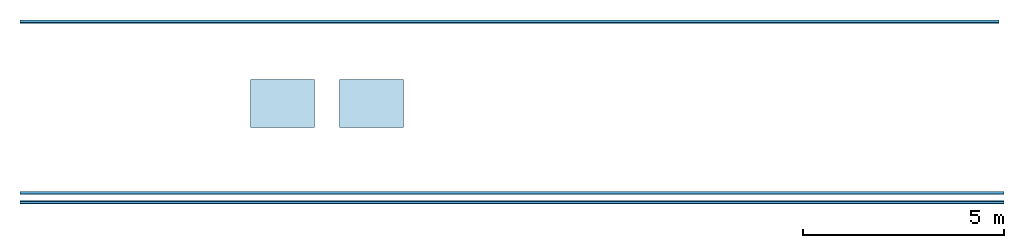
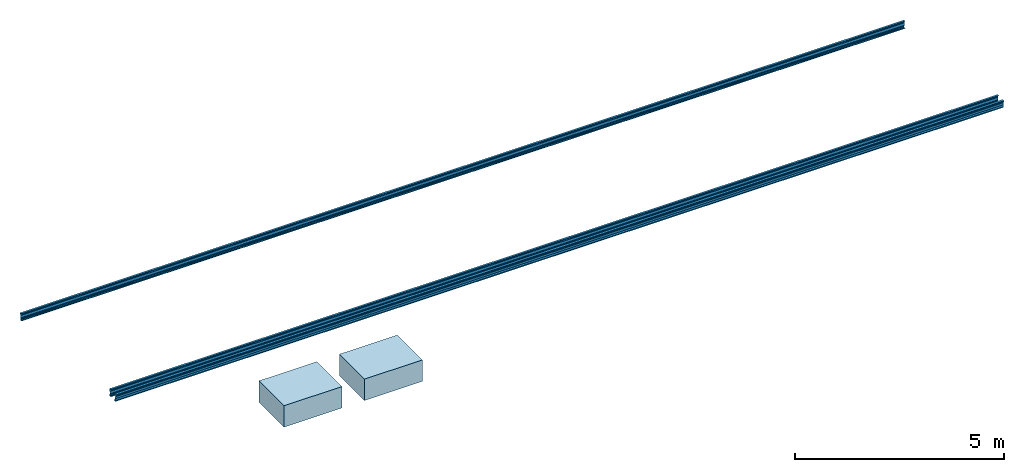
# One storey: 3 beams, 2 slabs.
"""IFC2X3 building model written with IfcOpenShell, lengths in millimetres."""

from ifc_helpers import new_model, entity, si_unit, converted_unit, money_unit, point, direction, frame, frame_2d, origin_with_axes, place, context, subcontext, project, spatial, polyline, circle_curve, parameter, trimmed, segment, composite_curve, outline, extrude, material, layer, layer_set, layer_usage, type_object, element, save


model = new_model("IFC2X3")

# Units and contexts
model_context = context("Model", 3, precision=1e-05, world=origin_with_axes(), true_north=direction((0.0, 1.0)))
body_context = subcontext(model_context, "Body", "Model", "MODEL_VIEW")
ifc_project = project(units=[si_unit("LENGTHUNIT", "METRE", prefix="MILLI"), si_unit("AREAUNIT", "SQUARE_METRE"), si_unit("VOLUMEUNIT", "CUBIC_METRE"), converted_unit("PLANEANGLEUNIT", "DEGREE", entity("IfcPlaneAngleMeasure", 0.0174532925199), si_unit("PLANEANGLEUNIT", "RADIAN"), dimensions=[0, 0, 0, 0, 0, 0, 0]), si_unit("SOLIDANGLEUNIT", "STERADIAN"), money_unit("USD"), converted_unit("TIMEUNIT", "Year", entity("IfcTimeMeasure", 31556926.0), si_unit("TIMEUNIT", "SECOND"), dimensions=[0, 0, 0, 0, 0, 0, 0]), si_unit("MASSUNIT", "GRAM"), si_unit("THERMODYNAMICTEMPERATUREUNIT", "DEGREE_CELSIUS"), si_unit("LUMINOUSINTENSITYUNIT", "LUMEN")], contexts=[model_context])

# Site, building, storey
site_placement = place(None, origin_with_axes())
site = spatial("IfcSite", under=ifc_project, at=site_placement, CompositionType="ELEMENT")
building_placement = place(site_placement, origin_with_axes())
building = spatial("IfcBuilding", under=site, at=building_placement, CompositionType="ELEMENT")
storey_placement = place(building_placement, frame((0.0, 0.0, 74905.0), z_axis=(0.0, 0.0, 1.0), x_axis=(1.0, 0.0, 0.0)))
storey = spatial("IfcBuildingStorey", under=building, at=storey_placement, Name="RIDGE", CompositionType="ELEMENT", Elevation=74905.0)

# Beams
ifc_material_1 = material(Name="Metal - Steel 43-275")
beam_type_1 = type_object("IfcBeamType", PredefinedType="NOTDEFINED")
beam_1_placement = place(storey_placement, frame((16287.2045075, 7957.0357036, -578.908435604), z_axis=(0.0, 0.0, 1.0), x_axis=(0.0, 1.0, 0.0)))
element("IfcBeam", 1, at=beam_1_placement, inside=storey, type_object=beam_type_1, material=ifc_material_1, Name="Light Gauge-Kingspan Purlins:M", ObjectType="Light Gauge-Kingspan Purlins:M", context=body_context, shape_type="SweptSolid", body=[
    extrude(outline(composite_curve([segment(polyline([(-33.5333333333, -102.5), (25.0666666666, -102.5)]), True, "CONTINUOUS"), segment(trimmed(circle_curve(frame_2d((25.0666666666, -99.3), x_axis=(0.0, -1.0)), 3.2), [point((25.0666666666, -102.5)), parameter(0.0)], [point((28.2666666666, -99.3)), parameter(90.0)], True, "CARTESIAN"), True, "CONTINUOUS"), segment(polyline([(28.2666666666, -99.3), (28.2666666666, -91.7)]), True, "CONTINUOUS"), segment(trimmed(circle_curve(frame_2d((25.0666666666, -91.7), x_axis=(1.0, 0.0)), 3.2), [point((28.2666666666, -91.7)), parameter(0.0)], [point((25.0666666666, -88.5)), parameter(90.0)], True, "CARTESIAN"), True, "CONTINUOUS"), segment(polyline([(25.0666666666, -88.5), (16.2666666666, -88.5), (16.2666666666, -90.1), (25.0666666666, -90.1)]), True, "CONTINUOUS"), segment(trimmed(circle_curve(frame_2d((25.0666666666, -91.7), x_axis=(1.0, 0.0)), 1.6), [point((25.0666666666, -90.1)), parameter(90.0)], [point((26.6666666666, -91.7)), parameter(0.0)], False, "CARTESIAN"), True, "CONTINUOUS"), segment(polyline([(26.6666666666, -91.7), (26.6666666666, -99.3)]), True, "CONTINUOUS"), segment(trimmed(circle_curve(frame_2d((25.0666666666, -99.3), x_axis=(0.0, -1.0)), 1.6), [point((26.6666666666, -99.3)), parameter(90.0)], [point((25.0666666666, -100.9)), parameter(0.0)], False, "CARTESIAN"), True, "CONTINUOUS"), segment(polyline([(25.0666666666, -100.9), (-33.5333333334, -100.9)]), True, "CONTINUOUS"), segment(trimmed(circle_curve(frame_2d((-33.5333333334, -99.3), x_axis=(-1.0, 0.0)), 1.6), [point((-33.5333333334, -100.9)), parameter(90.0)], [point((-35.1333333334, -99.3)), parameter(0.0)], False, "CARTESIAN"), True, "CONTINUOUS"), segment(polyline([(-35.1333333334, -99.3), (-35.1333333334, -70.8953456886), (-15.1333333334, -32.8953456886), (-15.1333333334, 32.8953456886), (-35.1333333334, 70.8953456886), (-35.1333333334, 99.3)]), True, "CONTINUOUS"), segment(trimmed(circle_curve(frame_2d((-33.5333333334, 99.3), x_axis=(0.0, 1.0)), 1.6), [point((-35.1333333334, 99.3)), parameter(90.0)], [point((-33.5333333334, 100.9)), parameter(0.0)], False, "CARTESIAN"), True, "CONTINUOUS"), segment(polyline([(-33.5333333334, 100.9), (25.0666666666, 100.9)]), True, "CONTINUOUS"), segment(trimmed(circle_curve(frame_2d((25.0666666666, 99.3), x_axis=(1.0, 0.0)), 1.6), [point((25.0666666666, 100.9)), parameter(90.0)], [point((26.6666666666, 99.3)), parameter(0.0)], False, "CARTESIAN"), True, "CONTINUOUS"), segment(polyline([(26.6666666666, 99.3), (26.6666666666, 91.7)]), True, "CONTINUOUS"), segment(trimmed(circle_curve(frame_2d((25.0666666666, 91.7), x_axis=(0.0, -1.0)), 1.6), [point((26.6666666666, 91.7)), parameter(90.0)], [point((25.0666666666, 90.1)), parameter(0.0)], False, "CARTESIAN"), True, "CONTINUOUS"), segment(polyline([(25.0666666666, 90.1), (16.2666666666, 90.1), (16.2666666666, 88.5), (25.0666666666, 88.5)]), True, "CONTINUOUS"), segment(trimmed(circle_curve(frame_2d((25.0666666666, 91.7), x_axis=(0.0, -1.0)), 3.2), [point((25.0666666666, 88.5)), parameter(0.0)], [point((28.2666666666, 91.7)), parameter(90.0)], True, "CARTESIAN"), True, "CONTINUOUS"), segment(polyline([(28.2666666666, 91.7), (28.2666666666, 99.3)]), True, "CONTINUOUS"), segment(trimmed(circle_curve(frame_2d((25.0666666666, 99.3), x_axis=(1.0, 0.0)), 3.2), [point((28.2666666666, 99.3)), parameter(0.0)], [point((25.0666666666, 102.5)), parameter(90.0)], True, "CARTESIAN"), True, "CONTINUOUS"), segment(polyline([(25.0666666666, 102.5), (-33.5333333334, 102.5)]), True, "CONTINUOUS"), segment(trimmed(circle_curve(frame_2d((-33.5333333334, 99.3), x_axis=(0.0, 1.0)), 3.2), [point((-33.5333333334, 102.5)), parameter(0.0)], [point((-36.7333333334, 99.3)), parameter(90.0)], True, "CARTESIAN"), True, "CONTINUOUS"), segment(polyline([(-36.7333333334, 99.3), (-36.7333333334, 70.5), (-16.7333333334, 32.5), (-16.7333333334, -32.5), (-36.7333333334, -70.5), (-36.7333333334, -99.3)]), True, "CONTINUOUS"), segment(trimmed(circle_curve(frame_2d((-33.5333333334, -99.3), x_axis=(-1.0, 0.0)), 3.20000000005), [point((-36.7333333334, -99.3)), parameter(0.0)], [point((-33.5333333333, -102.5)), parameter(90.0)], True, "CARTESIAN"), True, "CONTINUOUS")], self_intersect=False)), frame((0.0, 24407.0, 0.0), z_axis=(0.0, -1.0, 0.0), x_axis=(-0.996194698092, 0.0, 0.0871557427478)), (0.0, 0.0, 1.0), 24407.0),
])
beam_2_placement = place(storey_placement, frame((16408.2045075, 3688.12246488, -205.541205561), z_axis=(0.0, 0.0, 1.0), x_axis=(0.0, 1.0, 0.0)))
element("IfcBeam", 2, at=beam_2_placement, inside=storey, type_object=beam_type_1, material=ifc_material_1, Name="Light Gauge-Kingspan Purlins:M", ObjectType="Light Gauge-Kingspan Purlins:M", context=body_context, shape_type="SweptSolid", body=[
    extrude(outline(composite_curve([segment(polyline([(-33.5333333333, -102.5), (25.0666666666, -102.5)]), True, "CONTINUOUS"), segment(trimmed(circle_curve(frame_2d((25.0666666666, -99.3), x_axis=(0.0, -1.0)), 3.2), [point((25.0666666666, -102.5)), parameter(0.0)], [point((28.2666666666, -99.3)), parameter(90.0)], True, "CARTESIAN"), True, "CONTINUOUS"), segment(polyline([(28.2666666666, -99.3), (28.2666666666, -91.7)]), True, "CONTINUOUS"), segment(trimmed(circle_curve(frame_2d((25.0666666666, -91.7), x_axis=(1.0, 0.0)), 3.2), [point((28.2666666666, -91.7)), parameter(0.0)], [point((25.0666666666, -88.5)), parameter(90.0)], True, "CARTESIAN"), True, "CONTINUOUS"), segment(polyline([(25.0666666666, -88.5), (16.2666666666, -88.5), (16.2666666666, -90.1), (25.0666666666, -90.1)]), True, "CONTINUOUS"), segment(trimmed(circle_curve(frame_2d((25.0666666666, -91.7), x_axis=(1.0, 0.0)), 1.6), [point((25.0666666666, -90.1)), parameter(90.0)], [point((26.6666666666, -91.7)), parameter(0.0)], False, "CARTESIAN"), True, "CONTINUOUS"), segment(polyline([(26.6666666666, -91.7), (26.6666666666, -99.3)]), True, "CONTINUOUS"), segment(trimmed(circle_curve(frame_2d((25.0666666666, -99.3), x_axis=(0.0, -1.0)), 1.6), [point((26.6666666666, -99.3)), parameter(90.0)], [point((25.0666666666, -100.9)), parameter(0.0)], False, "CARTESIAN"), True, "CONTINUOUS"), segment(polyline([(25.0666666666, -100.9), (-33.5333333334, -100.9)]), True, "CONTINUOUS"), segment(trimmed(circle_curve(frame_2d((-33.5333333334, -99.3), x_axis=(-1.0, 0.0)), 1.6), [point((-33.5333333334, -100.9)), parameter(90.0)], [point((-35.1333333334, -99.3)), parameter(0.0)], False, "CARTESIAN"), True, "CONTINUOUS"), segment(polyline([(-35.1333333334, -99.3), (-35.1333333334, -70.8953456886), (-15.1333333334, -32.8953456886), (-15.1333333334, 32.8953456886), (-35.1333333334, 70.8953456886), (-35.1333333334, 99.3)]), True, "CONTINUOUS"), segment(trimmed(circle_curve(frame_2d((-33.5333333334, 99.3), x_axis=(0.0, 1.0)), 1.6), [point((-35.1333333334, 99.3)), parameter(90.0)], [point((-33.5333333334, 100.9)), parameter(0.0)], False, "CARTESIAN"), True, "CONTINUOUS"), segment(polyline([(-33.5333333334, 100.9), (25.0666666666, 100.9)]), True, "CONTINUOUS"), segment(trimmed(circle_curve(frame_2d((25.0666666666, 99.3), x_axis=(1.0, 0.0)), 1.6), [point((25.0666666666, 100.9)), parameter(90.0)], [point((26.6666666666, 99.3)), parameter(0.0)], False, "CARTESIAN"), True, "CONTINUOUS"), segment(polyline([(26.6666666666, 99.3), (26.6666666666, 91.7)]), True, "CONTINUOUS"), segment(trimmed(circle_curve(frame_2d((25.0666666666, 91.7), x_axis=(0.0, -1.0)), 1.6), [point((26.6666666666, 91.7)), parameter(90.0)], [point((25.0666666666, 90.1)), parameter(0.0)], False, "CARTESIAN"), True, "CONTINUOUS"), segment(polyline([(25.0666666666, 90.1), (16.2666666666, 90.1), (16.2666666666, 88.5), (25.0666666666, 88.5)]), True, "CONTINUOUS"), segment(trimmed(circle_curve(frame_2d((25.0666666666, 91.7), x_axis=(0.0, -1.0)), 3.2), [point((25.0666666666, 88.5)), parameter(0.0)], [point((28.2666666666, 91.7)), parameter(90.0)], True, "CARTESIAN"), True, "CONTINUOUS"), segment(polyline([(28.2666666666, 91.7), (28.2666666666, 99.3)]), True, "CONTINUOUS"), segment(trimmed(circle_curve(frame_2d((25.0666666666, 99.3), x_axis=(1.0, 0.0)), 3.2), [point((28.2666666666, 99.3)), parameter(0.0)], [point((25.0666666666, 102.5)), parameter(90.0)], True, "CARTESIAN"), True, "CONTINUOUS"), segment(polyline([(25.0666666666, 102.5), (-33.5333333334, 102.5)]), True, "CONTINUOUS"), segment(trimmed(circle_curve(frame_2d((-33.5333333334, 99.3), x_axis=(0.0, 1.0)), 3.2), [point((-33.5333333334, 102.5)), parameter(0.0)], [point((-36.7333333334, 99.3)), parameter(90.0)], True, "CARTESIAN"), True, "CONTINUOUS"), segment(polyline([(-36.7333333334, 99.3), (-36.7333333334, 70.5), (-16.7333333334, 32.5), (-16.7333333334, -32.5), (-36.7333333334, -70.5), (-36.7333333334, -99.3)]), True, "CONTINUOUS"), segment(trimmed(circle_curve(frame_2d((-33.5333333334, -99.3), x_axis=(-1.0, 0.0)), 3.20000000005), [point((-36.7333333334, -99.3)), parameter(0.0)], [point((-33.5333333333, -102.5)), parameter(90.0)], True, "CARTESIAN"), True, "CONTINUOUS")], self_intersect=False)), frame((0.0, 24528.0, 0.0), z_axis=(0.0, -1.0, 0.0), x_axis=(-0.996194698092, 0.0, 0.0871557427478)), (0.0, 0.0, 1.0), 24528.0),
])
beam_type_2 = type_object("IfcBeamType", PredefinedType="NOTDEFINED")
beam_3_placement = place(storey_placement, frame((16408.2045075, 3466.83737851, -205.541205561), z_axis=(0.0, 0.0, 1.0), x_axis=(0.0, 1.0, 0.0)))
element("IfcBeam", 3, at=beam_3_placement, inside=storey, type_object=beam_type_2, material=ifc_material_1, Name="Light Gauge-Kingspan Purlins:M", ObjectType="Light Gauge-Kingspan Purlins:M", context=body_context, shape_type="SweptSolid", body=[
    extrude(outline(composite_curve([segment(polyline([(91.7, -28.2666666667), (99.3, -28.2666666667)]), True, "CONTINUOUS"), segment(trimmed(circle_curve(frame_2d((99.3, -25.0666666667), x_axis=(0.0, -1.0)), 3.2), [point((99.3, -28.2666666667)), parameter(0.0)], [point((102.5, -25.0666666667)), parameter(90.0)], True, "CARTESIAN"), True, "CONTINUOUS"), segment(polyline([(102.5, -25.0666666667), (102.5, 33.5333333333)]), True, "CONTINUOUS"), segment(trimmed(circle_curve(frame_2d((99.3, 33.5333333333), x_axis=(1.0, 0.0)), 3.2), [point((102.5, 33.5333333333)), parameter(0.0)], [point((99.3, 36.7333333333)), parameter(90.0)], True, "CARTESIAN"), True, "CONTINUOUS"), segment(polyline([(99.3, 36.7333333333), (70.5, 36.7333333333), (32.5, 16.7333333333), (-32.5, 16.7333333333), (-70.5, 36.7333333334), (-99.3, 36.7333333334)]), True, "CONTINUOUS"), segment(trimmed(circle_curve(frame_2d((-99.3, 33.5333333334), x_axis=(0.0, 1.0)), 3.2), [point((-99.3, 36.7333333334)), parameter(0.0)], [point((-102.5, 33.5333333334)), parameter(90.0)], True, "CARTESIAN"), True, "CONTINUOUS"), segment(polyline([(-102.5, 33.5333333334), (-102.5, -25.0666666666)]), True, "CONTINUOUS"), segment(trimmed(circle_curve(frame_2d((-99.3, -25.0666666666), x_axis=(-1.0, 0.0)), 3.2), [point((-102.5, -25.0666666666)), parameter(0.0)], [point((-99.3, -28.2666666666)), parameter(90.0)], True, "CARTESIAN"), True, "CONTINUOUS"), segment(polyline([(-99.3, -28.2666666666), (-91.7, -28.2666666666)]), True, "CONTINUOUS"), segment(trimmed(circle_curve(frame_2d((-91.7, -25.0666666666), x_axis=(0.0, -1.0)), 3.2), [point((-91.7, -28.2666666666)), parameter(0.0)], [point((-88.5, -25.0666666666)), parameter(90.0)], True, "CARTESIAN"), True, "CONTINUOUS"), segment(polyline([(-88.5, -25.0666666666), (-88.5, -16.2666666666), (-90.1, -16.2666666666), (-90.1, -25.0666666666)]), True, "CONTINUOUS"), segment(trimmed(circle_curve(frame_2d((-91.7, -25.0666666666), x_axis=(0.0, -1.0)), 1.6), [point((-90.1, -25.0666666666)), parameter(90.0)], [point((-91.7, -26.6666666666)), parameter(0.0)], False, "CARTESIAN"), True, "CONTINUOUS"), segment(polyline([(-91.7, -26.6666666666), (-99.3, -26.6666666666)]), True, "CONTINUOUS"), segment(trimmed(circle_curve(frame_2d((-99.3, -25.0666666666), x_axis=(-1.0, 0.0)), 1.6), [point((-99.3, -26.6666666666)), parameter(90.0)], [point((-100.9, -25.0666666666)), parameter(0.0)], False, "CARTESIAN"), True, "CONTINUOUS"), segment(polyline([(-100.9, -25.0666666666), (-100.9, 33.5333333334)]), True, "CONTINUOUS"), segment(trimmed(circle_curve(frame_2d((-99.3, 33.5333333334), x_axis=(0.0, 1.0)), 1.6), [point((-100.9, 33.5333333334)), parameter(90.0)], [point((-99.3, 35.1333333334)), parameter(0.0)], False, "CARTESIAN"), True, "CONTINUOUS"), segment(polyline([(-99.3, 35.1333333334), (-70.8953456886, 35.1333333334), (-32.8953456886, 15.1333333333), (32.8953456886, 15.1333333333), (70.8953456886, 35.1333333333), (99.3, 35.1333333333)]), True, "CONTINUOUS"), segment(trimmed(circle_curve(frame_2d((99.3, 33.5333333333), x_axis=(1.0, 0.0)), 1.6), [point((99.3, 35.1333333333)), parameter(90.0)], [point((100.9, 33.5333333333)), parameter(0.0)], False, "CARTESIAN"), True, "CONTINUOUS"), segment(polyline([(100.9, 33.5333333333), (100.9, -25.0666666667)]), True, "CONTINUOUS"), segment(trimmed(circle_curve(frame_2d((99.3, -25.0666666667), x_axis=(0.0, -1.0)), 1.6), [point((100.9, -25.0666666667)), parameter(90.0)], [point((99.3, -26.6666666667)), parameter(0.0)], False, "CARTESIAN"), True, "CONTINUOUS"), segment(polyline([(99.3, -26.6666666667), (91.7, -26.6666666667)]), True, "CONTINUOUS"), segment(trimmed(circle_curve(frame_2d((91.7, -25.0666666667), x_axis=(-1.0, 0.0)), 1.6), [point((91.7, -26.6666666667)), parameter(90.0)], [point((90.1, -25.0666666667)), parameter(0.0)], False, "CARTESIAN"), True, "CONTINUOUS"), segment(polyline([(90.1, -25.0666666667), (90.1, -16.2666666667), (88.5, -16.2666666667), (88.5, -25.0666666667)]), True, "CONTINUOUS"), segment(trimmed(circle_curve(frame_2d((91.7, -25.0666666667), x_axis=(-1.0, 0.0)), 3.2), [point((88.5, -25.0666666667)), parameter(0.0)], [point((91.7, -28.2666666667)), parameter(90.0)], True, "CARTESIAN"), True, "CONTINUOUS")], self_intersect=False)), frame((0.0, 24528.0, 0.0), z_axis=(0.0, -1.0, 0.0), x_axis=(-0.0871557427479, 0.0, 0.996194698092)), (0.0, 0.0, 1.0), 24528.0),
])

# Slabs
ifc_material_2 = material(Name="Concrete, Precast")
ifc_layer = layer(ifc_material_2, 624.90349002, ventilated="UNKNOWN")
ifc_layer_set = layer_set([ifc_layer])
ifc_layer_usage_1 = layer_usage(ifc_layer_set, "AXIS3", "NEGATIVE", 624.90349002)
slab_type = type_object("IfcSlabType", Name="Concrete, Precast 625", PredefinedType="FLOOR")
slab_1_placement = place(storey_placement, frame((-159.981247588, 6517.48339185, -4205.0), z_axis=(0.0, 0.0, 1.0), x_axis=(1.0, 0.0, 0.0)))
element("IfcSlab", 4, at=slab_1_placement, inside=storey, type_object=slab_type, material=ifc_layer_usage_1, Name="Concrete Plinth_4:Concrete Plinth_1", ObjectType="Concrete Plinth_4:Concrete Plinth_1", PredefinedType="FLOOR", context=body_context, shape_type="SweptSolid", body=[
    extrude(outline(polyline([(0.0, 0.0), (0.0, -1199.99721622), (1600.0, -1199.99721622), (1600.0, 0.0), (0.0, 0.0)])), origin_with_axes(), (0.0, 0.0, 1.0), 624.90349002),
])
ifc_layer_usage_2 = layer_usage(ifc_layer_set, "AXIS3", "NEGATIVE", 624.90349002)
slab_2_placement = place(storey_placement, frame((-2379.49648379, 6517.48339185, -4205.0), z_axis=(0.0, 0.0, 1.0), x_axis=(1.0, 0.0, 0.0)))
element("IfcSlab", 5, at=slab_2_placement, inside=storey, type_object=slab_type, material=ifc_layer_usage_2, Name="Concrete Plinth_3:Concrete Plinth_1", ObjectType="Concrete Plinth_3:Concrete Plinth_1", PredefinedType="FLOOR", context=body_context, shape_type="SweptSolid", body=[
    extrude(outline(polyline([(0.0, 0.0), (0.0, -1199.99721622), (1600.00208783, -1199.99721622), (1600.00208783, 0.0), (0.0, 0.0)])), origin_with_axes(), (0.0, 0.0, 1.0), 624.90349002),
])

save(model, "model.ifc")
